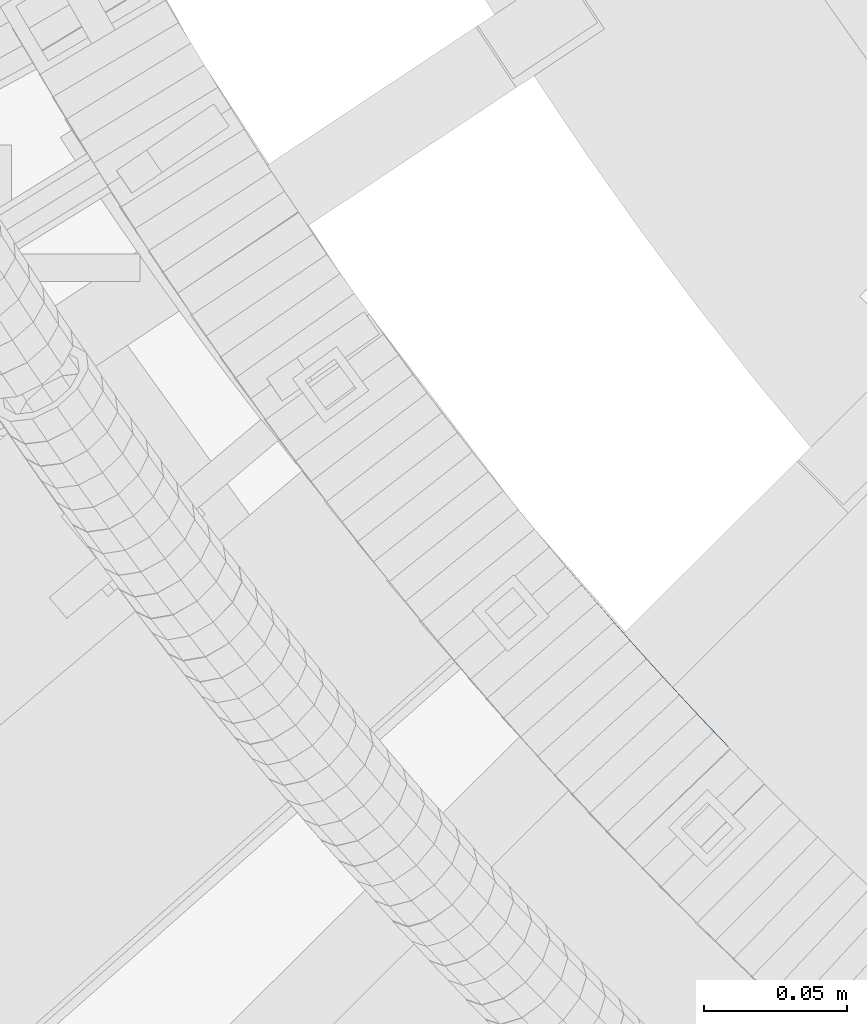
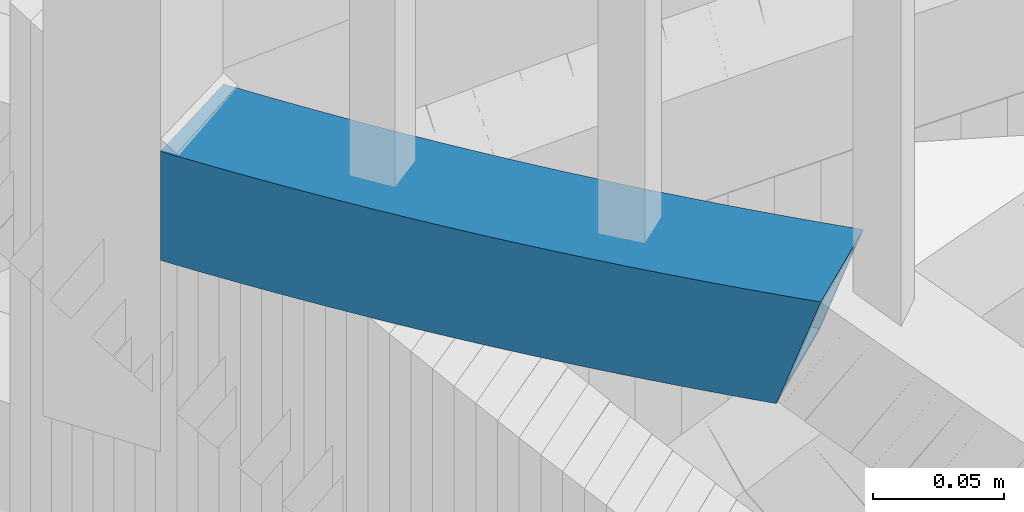
# One storey, part 474 of 975: 1 beam.
"""IFC2X3 building model written with IfcOpenShell, lengths in millimetres."""

from ifc_helpers import new_model, si_unit, frame, origin_with_axes, place, context, subcontext, project, spatial, faceted_brep, material, type_object, element, save


model = new_model("IFC2X3")

# Units and contexts
model_context = context("Model", 3, precision=1e-05, world=origin_with_axes())
body_context = subcontext(model_context, "Body", "Model", "MODEL_VIEW")
ifc_project = project(units=[si_unit("LENGTHUNIT", "METRE", prefix="MILLI"), si_unit("AREAUNIT", "SQUARE_METRE"), si_unit("VOLUMEUNIT", "CUBIC_METRE"), si_unit("MASSUNIT", "GRAM", prefix="KILO"), si_unit("TIMEUNIT", "SECOND"), si_unit("PLANEANGLEUNIT", "RADIAN"), si_unit("SOLIDANGLEUNIT", "STERADIAN"), si_unit("THERMODYNAMICTEMPERATUREUNIT", "DEGREE_CELSIUS"), si_unit("LUMINOUSINTENSITYUNIT", "LUMEN")], contexts=[model_context])

# Site, building, storey
site_placement = place(None, origin_with_axes())
site = spatial("IfcSite", under=ifc_project, at=site_placement, CompositionType="ELEMENT")
building_placement = place(site_placement, origin_with_axes())
building = spatial("IfcBuilding", under=site, at=building_placement, Name="Undefined", CompositionType="ELEMENT")
storey_placement = place(building_placement, origin_with_axes())
storey = spatial("IfcBuildingStorey", under=building, at=storey_placement, Name="Undefined", CompositionType="ELEMENT", Elevation=0.0)

# Beam
ifc_material = material()
beam_type = type_object("IfcBeamType", Name="HSS2X2X.188_TUBES", PredefinedType="NOTDEFINED")
beam_placement = place(storey_placement, frame((33730.3437735476, 2432.37434502385, 4254.5), z_axis=(0.0, 0.0, 1.0), x_axis=(-0.614732272176384, 0.788735845226309, 0.0)))
element("IfcBeam", 1, at=beam_placement, inside=storey, type_object=beam_type, material=ifc_material, Name="HANDRAIL", ObjectType="HSS2X2X.188_TUBES", context=body_context, shape_type="Brep", body=[
    faceted_brep([(7.5286119618213, 26.3140467708836, 25.3999999999996), (7.5286119618213, 26.3140467708836, 15.6138958555184), (4.14886245549496, 25.9706449751648, 25.3999999999996), (12.6480240895398, 26.8155101962911, 25.3999999999996), (12.6480240895398, 26.8155101962911, 0.793814656849463), (17.7692162116036, 27.298456724704, 25.3999999999996), (17.7692162116036, 27.298456724704, -14.0281842069107), (260.234750728057, -21.9957919031367, 25.3999999999996), (260.234750728057, -21.9957919031367, -25.3999999999996), (265.177804815132, -22.407887995374, -25.3999999999996), (265.177804815132, -22.407887995374, 25.3999999999996), (255.290238677531, -21.6015743500284, 25.3999999999996), (255.290238677531, -21.6015743500284, -25.3999999999996), (250.344333328252, -21.2252404916435, 25.3999999999996), (250.344333328252, -21.2252404916435, -25.3999999999996), (245.397099363145, -20.866795249709, 25.3999999999996), (245.397099363145, -20.866795249709, -25.3999999999996), (240.448601482509, -20.5262433119933, 25.3999999999996), (240.448601482509, -20.5262433119933, -25.3999999999996), (235.498904403161, -20.2035891322703, 25.3999999999996), (235.498904403161, -20.2035891322703, -25.3999999999996), (230.548072857622, -19.8988369302206, 25.3999999999996), (230.548072857622, -19.8988369302206, -25.3999999999996), (225.596171593232, -19.6119906914282, 25.3999999999996), (225.596171593232, -19.6119906914282, -25.3999999999996), (220.643265371331, -19.3430541672897, 25.3999999999996), (220.643265371331, -19.3430541672897, -25.3999999999996), (215.689418966394, -19.0920308749701, 25.3999999999996), (215.689418966394, -19.0920308749701, -25.3999999999996), (210.734697165204, -18.8589240973779, 25.3999999999996), (210.734697165204, -18.8589240973779, -25.3999999999996), (205.779164765976, -18.643736883103, 25.3999999999996), (205.779164765976, -18.643736883103, -25.3999999999996), (200.822886577538, -18.4464720463693, 25.3999999999996), (200.822886577538, -18.4464720463693, -25.3999999999996), (195.865927418476, -18.2671321670205, 25.3999999999996), (195.865927418476, -18.2671321670205, -25.3999999999996), (190.908352116261, -18.1057195904941, 25.3999999999996), (190.908352116261, -18.1057195904941, -25.3999999999996), (185.950225506444, -17.9622364277457, 25.3999999999996), (185.950225506444, -17.9622364277457, -25.3999999999996), (180.991612431775, -17.8366845552518, 25.3999999999996), (180.991612431775, -17.8366845552518, -25.3999999999996), (176.032577741364, -17.7290656149999, 25.3999999999996), (176.032577741364, -17.7290656149999, -25.3999999999996), (171.073186289846, -17.6393810144327, 25.3999999999996), (171.073186289846, -17.6393810144327, -25.3999999999996), (166.113502936514, -17.567631926453, 25.3999999999996), (166.113502936514, -17.567631926453, -25.3999999999996), (161.153592544477, -17.513819289401, 25.3999999999996), (161.153592544477, -17.513819289401, -25.3999999999996), (156.193519979806, -17.4779438070473, 25.3999999999996), (156.193519979806, -17.4779438070473, -25.3999999999996), (151.233350110724, -17.4600059485674, 25.3999999999996), (151.233350110724, -17.4600059485674, -25.3999999999996), (146.273147806685, -17.4600059485565, 25.3999999999996), (146.273147806685, -17.4600059485565, -25.3999999999996), (141.312977937596, -17.4779438070145, 25.3999999999996), (141.312977937596, -17.4779438070145, -25.3999999999996), (136.352905372933, -17.5138192893464, 25.3999999999996), (136.352905372933, -17.5138192893464, -25.3999999999996), (131.392994980895, -17.5676319263766, 25.3999999999996), (131.392994980895, -17.5676319263766, -25.3999999999996), (126.433311627556, -17.6393810143345, 25.3999999999996), (126.433311627556, -17.6393810143345, -25.3999999999996), (121.473920176039, -17.7290656148798, 25.3999999999996), (121.473920176039, -17.7290656148798, -25.3999999999996), (116.514885485631, -17.8366845551136, 25.3999999999996), (116.514885485631, -17.8366845551136, -25.3999999999996), (111.556272410962, -17.962236427582, 25.3999999999996), (111.556272410962, -17.962236427582, -25.3999999999996), (106.598145801145, -18.1057195903122, 25.3999999999996), (106.598145801145, -18.1057195903122, -25.3999999999996), (101.640570498934, -18.2671321668167, 25.3999999999996), (101.640570498934, -18.2671321668167, -25.3999999999996), (96.6836113398676, -18.4464720461401, 25.3999999999996), (96.6836113398676, -18.4464720461401, -25.3999999999996), (91.7273331514261, -18.6437368828556, 25.3999999999996), (91.7273331514261, -18.6437368828556, -25.3999999999996), (86.7718007522053, -18.8589240971087, 25.3999999999996), (86.7718007522053, -18.8589240971087, -25.3999999999996), (81.8170789510077, -19.092030874679, 25.3999999999996), (81.8170789510077, -19.092030874679, -25.3999999999996), (76.8632325460712, -19.3430541669768, 25.3999999999996), (76.8632325460712, -19.3430541669768, -25.3999999999996), (71.9103263241741, -19.6119906910899, 25.3999999999996), (71.9103263241741, -19.6119906910899, -25.3999999999996), (66.9584250597836, -19.8988369298604, 25.3999999999996), (66.9584250597836, -19.8988369298604, -25.3999999999996), (62.0075935142377, -20.2035891318883, 25.3999999999996), (62.0075935142377, -20.2035891318883, -25.3999999999996), (57.0578964348933, -20.5262433115895, 25.3999999999996), (57.0578964348933, -20.5262433115895, -25.3999999999996), (52.1093985542502, -20.866795249287, 25.3999999999996), (52.1093985542502, -20.866795249287, -25.3999999999996), (47.1621645891464, -21.225240491196, 25.3999999999996), (47.1621645891464, -21.225240491196, -25.3999999999996), (42.2162592398672, -21.6015743495627, 25.3999999999996), (42.2162592398672, -21.6015743495627, -25.3999999999996), (37.2717471893448, -21.9957919026492, 25.3999999999996), (37.2717471893448, -21.9957919026492, -25.3999999999996), (32.3286931022631, -22.4078879948647, 25.3999999999996), (32.3286931022631, -22.4078879948647, -25.3999999999996), (27.3871616242759, -22.8378572367656, 25.3999999999996), (27.3871616242759, -22.8378572367656, -25.3999999999996), (7.63755400110313, -24.7363497333245, 25.3999999999996), (7.20128584808845, -24.7822716471164, 25.3999999999996), (7.63755400110313, -24.7363497333245, 24.1365044695722), (12.5723489973643, -24.2349464606777, 25.3999999999996), (12.5723489973643, -24.2349464606777, 9.8477479582516), (17.5089249776647, -23.7513924433151, 25.3999999999996), (17.5089249776647, -23.7513924433151, -4.44304462617947), (22.4472173810864, -23.2856940052006, 25.3999999999996), (22.4472173810864, -23.2856940052006, -18.7356863876621), (24.7503262013524, -23.0769028203904, -25.3999999999996), (265.582056745192, -17.6625759269082, -20.6374999999998), (265.582056745192, -17.6625759269082, 20.6374999999998), (270.028364761973, -18.0494551152515, 20.6374999999998), (270.028364761973, -18.0494551152515, -20.6374999999998), (260.621839275871, -17.2490489454685, -20.6374999999998), (260.621839275871, -17.2490489454685, 20.6374999999998), (255.660158780724, -16.85346258141, -20.6374999999998), (255.660158780724, -16.85346258141, 20.6374999999998), (250.697080148988, -16.4758220082331, -20.6374999999998), (250.697080148988, -16.4758220082331, 20.6374999999998), (245.732668288165, -16.1161321647669, -20.6374999999998), (245.732668288165, -16.1161321647669, 20.6374999999998), (240.766988123221, -15.7743977550454, -20.6374999999998), (240.766988123221, -15.7743977550454, 20.6374999999998), (235.800104595684, -15.4506232483072, -20.6374999999998), (235.800104595684, -15.4506232483072, 20.6374999999998), (230.83208266283, -15.1448128788943, -20.6374999999998), (230.83208266283, -15.1448128788943, 20.6374999999998), (225.862987296827, -14.8569706462185, -20.6374999999998), (225.862987296827, -14.8569706462185, 20.6374999999998), (220.892883483881, -14.587100314704, -20.6374999999998), (220.892883483881, -14.587100314704, 20.6374999999998), (215.921836223373, -14.3352054137285, -20.6374999999998), (215.921836223373, -14.3352054137285, 20.6374999999998), (210.949910527033, -14.1012892376057, -20.6374999999998), (210.949910527033, -14.1012892376057, 20.6374999999998), (205.97717141809, -13.8853548455008, -20.6374999999998), (205.97717141809, -13.8853548455008, 20.6374999999998), (201.003683930387, -13.6874050614206, -20.6374999999998), (201.003683930387, -13.6874050614206, 20.6374999999998), (196.029513107576, -13.5074424741579, -20.6374999999998), (196.029513107576, -13.5074424741579, 20.6374999999998), (191.054724002228, -13.3454694372922, -20.6374999999998), (191.054724002228, -13.3454694372922, 20.6374999999998), (186.079381675019, -13.2014880691167, -20.6374999999998), (186.079381675019, -13.2014880691167, 20.6374999999998), (181.103551193839, -13.0755002526203, -20.6374999999998), (181.103551193839, -13.0755002526203, 20.6374999999998), (176.127297632978, -12.9675076354906, -20.6374999999998), (176.127297632978, -12.9675076354906, 20.6374999999998), (171.150686072255, -12.8775116300603, -20.6374999999998), (171.150686072255, -12.8775116300603, 20.6374999999998), (166.173781596161, -12.8055134133101, -20.6374999999998), (166.173781596161, -12.8055134133101, 20.6374999999998), (161.196649293041, -12.7515139268216, -20.6374999999998), (161.196649293041, -12.7515139268216, 20.6374999999998), (156.219354254197, -12.7155138768176, -20.6374999999998), (156.219354254197, -12.7155138768176, 20.6374999999998), (151.241961573061, -12.6975137341033, -20.6374999999998), (151.241961573061, -12.6975137341033, 20.6374999999998), (146.264536344359, -12.697513734096, -20.6374999999998), (146.264536344359, -12.697513734096, 20.6374999999998), (141.287143663223, -12.7155138767885, -20.6374999999998), (141.287143663223, -12.7155138767885, 20.6374999999998), (136.309848624376, -12.7515139267671, -20.6374999999998), (136.309848624376, -12.7515139267671, 20.6374999999998), (131.332716321256, -12.8055134132264, -20.6374999999998), (131.332716321256, -12.8055134132264, 20.6374999999998), (126.355811845166, -12.8775116299694, -20.6374999999998), (126.355811845166, -12.8775116299694, 20.6374999999998), (121.379200284438, -12.9675076353778, -20.6374999999998), (121.379200284438, -12.9675076353778, 20.6374999999998), (116.402946723581, -13.075500252482, -20.6374999999998), (116.402946723581, -13.075500252482, 20.6374999999998), (111.427116242401, -13.2014880689494, -20.6374999999998), (111.427116242401, -13.2014880689494, 20.6374999999998), (106.451773915189, -13.3454694371067, -20.6374999999998), (106.451773915189, -13.3454694371067, 20.6374999999998), (101.476984809837, -13.5074424739541, -20.6374999999998), (101.476984809837, -13.5074424739541, 20.6374999999998), (96.5028139870265, -13.6874050611877, -20.6374999999998), (96.5028139870265, -13.6874050611877, 20.6374999999998), (91.529326499327, -13.8853548452462, -20.6374999999998), (91.529326499327, -13.8853548452462, 20.6374999999998), (86.5565873903797, -14.1012892373328, -20.6374999999998), (86.5565873903797, -14.1012892373328, 20.6374999999998), (81.5846616940435, -14.3352054134375, -20.6374999999998), (81.5846616940435, -14.3352054134375, 20.6374999999998), (76.6136144335323, -14.5871003143875, -20.6374999999998), (76.6136144335323, -14.5871003143875, 20.6374999999998), (71.6435106205827, -14.8569706458802, -20.6374999999998), (71.6435106205827, -14.8569706458802, 20.6374999999998), (66.6744152545834, -15.1448128785341, -20.6374999999998), (66.6744152545834, -15.1448128785341, 20.6374999999998), (61.7063933217287, -15.4506232479253, -20.6374999999998), (61.7063933217287, -15.4506232479253, 20.6374999999998), (56.7395097941881, -15.7743977546452, -20.6374999999998), (56.7395097941881, -15.7743977546452, 20.6374999999998), (51.7738296292446, -16.1161321643449, -20.6374999999998), (51.7738296292446, -16.1161321643449, 20.6374999999998), (46.8094177684216, -16.4758220077929, -20.6374999999998), (46.8094177684216, -16.4758220077929, 20.6374999999998), (41.8463391366822, -16.8534625809407, -20.6374999999998), (41.8463391366822, -16.8534625809407, 20.6374999999998), (36.8846586415384, -17.249048944981, -20.6374999999998), (36.8846586415384, -17.249048944981, 20.6374999999998), (31.9244411722138, -17.6625759263989, -20.6374999999998), (31.9244411722138, -17.6625759263989, 20.6374999999998), (26.965751598811, -18.0940381170622, -20.6374999999998), (26.965751598811, -18.0940381170622, 20.6374999999998), (22.0086547714454, -18.5434298742766, 20.6374999999998), (22.8184172146866, -18.4700198562787, -20.6374999999998), (22.0086547714454, -18.5434298742766, -18.2943580582169), (17.0532155194014, -19.0107453208511, 20.6374999999998), (17.0532155194014, -19.0107453208511, -3.95208906839616), (12.099498650281, -19.4959783452214, 20.6374999999998), (12.099498650281, -19.4959783452214, 10.3883243236205), (8.55982178591876, -19.8556296712122, 20.6374999999998), (6.07980522722573, 21.3798273531102, 20.6374999999998), (8.00146230890095, 21.5750786554236, 20.6374999999998), (13.1037335477959, 22.0748630738235, 20.6374999999998), (18.2077788212409, 22.5561925937727, 20.6374999999998), (23.3135313781495, 23.0190609204037, 20.6374999999998), (28.4209244451049, 23.4634620002944, 20.6374999999998), (33.5298912272301, 23.8893900215262, 20.6374999999998), (38.6403649090789, 24.2968394137788, 20.6374999999998), (43.7522786555019, 24.68580484841, 20.6374999999998), (48.8655656124902, 25.0562812384924, 20.6374999999998), (53.9801589081071, 25.4082637389038, 20.6374999999998), (59.0959916533066, 25.7417477464005, 20.6374999999998), (64.2129969428534, 26.0567288996463, 20.6374999999998), (69.3311078561674, 26.3532030792994, 20.6374999999998), (74.4502574582039, 26.6311664080531, 20.6374999999998), (79.5703788003411, 26.8906152506679, 20.6374999999998), (84.6914049212537, 27.1315462140628, 20.6374999999998), (89.8132688477672, 27.3539561473117, 20.6374999999998), (94.9359035957677, 27.5578421417376, 20.6374999999998), (100.059242171053, 27.743201530895, 20.6374999999998), (105.183217570218, 27.9100318906421, 20.6374999999998), (110.307762781522, 28.058331039163, 20.6374999999998), (115.43281078578, 28.1880970369821, 20.6374999999998), (120.558294557228, 28.2993281870113, 20.6374999999998), (125.684147064418, 28.3920230345684, 20.6374999999998), (130.810301271045, 28.4661803673735, 20.6374999999998), (135.936690136892, 28.5217992155995, 20.6374999999998), (141.063246618658, 28.5588788518544, 20.6374999999998), (146.189903670849, 28.5774187912066, 20.6374999999998), (151.316594246662, 28.5774187911993, 20.6374999999998), (156.443251298857, 28.558878851818, 20.6374999999998), (161.569807780623, 28.5217992155413, 20.6374999999998), (166.696196646466, 28.4661803672934, 20.6374999999998), (171.822350853101, 28.3920230344665, 20.6374999999998), (176.948203360284, 28.2993281868912, 20.6374999999998), (182.073687131731, 28.1880970368329, 20.6374999999998), (187.198735135993, 28.058331038992, 20.6374999999998), (192.323280347297, 27.910031890453, 20.6374999999998), (197.447255746458, 27.743201530684, 20.6374999999998), (202.57059432174, 27.5578421415048, 20.6374999999998), (207.693229069748, 27.353956147057, 20.6374999999998), (212.815092996258, 27.1315462137791, 20.6374999999998), (217.93611911717, 26.890615250366, 20.6374999999998), (223.056240459307, 26.631166407722, 20.6374999999998), (228.17539006134, 26.3532030789538, 20.6374999999998), (233.293500974651, 26.0567288992825, 20.6374999999998), (238.410506264197, 25.7417477460076, 20.6374999999998), (243.526339009401, 25.408263738489, 20.6374999999998), (248.640932305014, 25.0562812380522, 20.6374999999998), (253.754219262009, 24.685804847948, 20.6374999999998), (258.866133008425, 24.2968394133022, 20.6374999999998), (263.976606690274, 23.8893900210169, 20.6374999999998), (269.085573472403, 23.4634619997669, 20.6374999999998), (274.192966539351, 23.019060919858, 20.6374999999998), (8.00146230890095, 21.5750786554236, 15.0733194901495), (13.1037335477959, 22.0748630738235, 0.302859099065245), (18.2077788212409, 22.5561925937727, -14.469512536356), (23.3135313781495, 23.0190609204037, -20.6374999999998), (20.3393631309191, 22.7494340114717, -20.6374999999998), (28.4209244451049, 23.4634620002944, -20.6374999999998), (33.5298912272301, 23.8893900215262, -20.6374999999998), (38.6403649090789, 24.2968394137788, -20.6374999999998), (43.7522786555019, 24.68580484841, -20.6374999999998), (48.8655656124902, 25.0562812384924, -20.6374999999998), (53.9801589081071, 25.4082637389038, -20.6374999999998), (59.0959916533066, 25.7417477464005, -20.6374999999998), (64.2129969428534, 26.0567288996463, -20.6374999999998), (69.3311078561674, 26.3532030792994, -20.6374999999998), (74.4502574582039, 26.6311664080531, -20.6374999999998), (79.5703788003411, 26.8906152506679, -20.6374999999998), (84.6914049212537, 27.1315462140628, -20.6374999999998), (89.8132688477672, 27.3539561473117, -20.6374999999998), (94.9359035957677, 27.5578421417376, -20.6374999999998), (100.059242171053, 27.743201530895, -20.6374999999998), (105.183217570218, 27.9100318906421, -20.6374999999998), (110.307762781522, 28.058331039163, -20.6374999999998), (115.43281078578, 28.1880970369821, -20.6374999999998), (120.558294557228, 28.2993281870113, -20.6374999999998), (125.684147064418, 28.3920230345684, -20.6374999999998), (130.810301271045, 28.4661803673735, -20.6374999999998), (135.936690136892, 28.5217992155995, -20.6374999999998), (141.063246618658, 28.5588788518544, -20.6374999999998), (146.189903670849, 28.5774187912066, -20.6374999999998), (151.316594246662, 28.5774187911993, -20.6374999999998), (156.443251298857, 28.558878851818, -20.6374999999998), (161.569807780623, 28.5217992155413, -20.6374999999998), (166.696196646466, 28.4661803672934, -20.6374999999998), (171.822350853101, 28.3920230344665, -20.6374999999998), (176.948203360284, 28.2993281868912, -20.6374999999998), (182.073687131731, 28.1880970368329, -20.6374999999998), (187.198735135993, 28.058331038992, -20.6374999999998), (192.323280347297, 27.910031890453, -20.6374999999998), (197.447255746458, 27.743201530684, -20.6374999999998), (202.57059432174, 27.5578421415048, -20.6374999999998), (207.693229069748, 27.353956147057, -20.6374999999998), (212.815092996258, 27.1315462137791, -20.6374999999998), (217.93611911717, 26.890615250366, -20.6374999999998), (223.056240459307, 26.631166407722, -20.6374999999998), (228.17539006134, 26.3532030789538, -20.6374999999998), (233.293500974651, 26.0567288992825, -20.6374999999998), (238.410506264197, 25.7417477460076, -20.6374999999998), (243.526339009401, 25.408263738489, -20.6374999999998), (248.640932305014, 25.0562812380522, -20.6374999999998), (253.754219262009, 24.685804847948, -20.6374999999998), (258.866133008425, 24.2968394133022, -20.6374999999998), (263.976606690274, 23.8893900210169, -20.6374999999998), (269.085573472403, 23.4634619997669, -20.6374999999998), (274.192966539351, 23.019060919858, -20.6374999999998), (21.6991827136299, 27.6547327091394, -25.3999999999996), (22.8921213526883, 27.7628800401144, 25.3999999999996), (22.8921213526883, 27.7628800401144, -25.3999999999996), (28.0166725150484, 28.2087740687602, 25.3999999999996), (28.0166725150484, 28.2087740687602, -25.3999999999996), (33.1428026794274, 28.636132979198, 25.3999999999996), (33.1428026794274, 28.636132979198, -25.3999999999996), (38.2704448058976, 29.0449511824045, 25.3999999999996), (38.2704448058976, 29.0449511824045, -25.3999999999996), (43.3995318347734, 29.4352233318132, 25.3999999999996), (43.3995318347734, 29.4352233318132, -25.3999999999996), (48.5299966874845, 29.8069443234344, 25.3999999999996), (48.5299966874845, 29.8069443234344, -25.3999999999996), (53.6617722674055, 30.1601092958517, 25.3999999999996), (53.6617722674055, 30.1601092958517, -25.3999999999996), (58.7947914608012, 30.4947136303599, 25.3999999999996), (58.7947914608012, 30.4947136303599, -25.3999999999996), (63.9289871376568, 30.8107529509762, 25.3999999999996), (63.9289871376568, 30.8107529509762, -25.3999999999996), (69.0642921525796, 31.1082231245164, 25.3999999999996), (69.0642921525796, 31.1082231245164, -25.3999999999996), (74.2006393456613, 31.3871202606388, 25.3999999999996), (74.2006393456613, 31.3871202606388, -25.3999999999996), (79.3379615433732, 31.6474407119094, 25.3999999999996), (79.3379615433732, 31.6474407119094, -25.3999999999996), (84.4761915594281, 31.8891810738351, 25.3999999999996), (84.4761915594281, 31.8891810738351, -25.3999999999996), (89.6152621956644, 32.1123381849175, 25.3999999999996), (89.6152621956644, 32.1123381849175, -25.3999999999996), (94.7551062429302, 32.3169091266936, 25.3999999999996), (94.7551062429302, 32.3169091266936, -25.3999999999996), (99.89565648196, 32.5028912237613, 25.3999999999996), (99.89565648196, 32.5028912237613, -25.3999999999996), (105.036845684252, 32.6702820438441, 25.3999999999996), (105.036845684252, 32.6702820438441, -25.3999999999996), (110.178606612953, 32.8190793977883, 25.3999999999996), (110.178606612953, 32.8190793977883, -25.3999999999996), (115.320872023727, 32.94928133961, 25.3999999999996), (115.320872023727, 32.94928133961, -25.3999999999996), (120.463574665628, 33.0608861665169, 25.3999999999996), (120.463574665628, 33.0608861665169, -25.3999999999996), (125.60664728202, 33.1538924189372, 25.3999999999996), (125.60664728202, 33.1538924189372, -25.3999999999996), (130.750022611406, 33.22829888052, 25.3999999999996), (130.750022611406, 33.22829888052, -25.3999999999996), (135.893633388336, 33.2841045781825, 25.3999999999996), (135.893633388336, 33.2841045781825, -25.3999999999996), (141.037412344282, 33.3213087820805, 25.3999999999996), (141.037412344282, 33.3213087820805, -25.3999999999996), (146.181292208519, 33.3399110056671, 25.3999999999996), (146.181292208519, 33.3399110056671, -25.3999999999996), (151.325205709007, 33.3399110056598, 25.3999999999996), (151.325205709007, 33.3399110056598, -25.3999999999996), (156.469085573244, 33.3213087820477, 25.3999999999996), (156.469085573244, 33.3213087820477, -25.3999999999996), (161.61286452919, 33.2841045781206, 25.3999999999996), (161.61286452919, 33.2841045781206, -25.3999999999996), (166.756475306123, 33.2282988804436, 25.3999999999996), (166.756475306123, 33.2282988804436, -25.3999999999996), (171.899850635502, 33.1538924188317, 25.3999999999996), (171.899850635502, 33.1538924188317, -25.3999999999996), (177.042923251891, 33.0608861663895, 25.3999999999996), (177.042923251891, 33.0608861663895, -25.3999999999996), (182.185625893799, 32.9492813394645, 25.3999999999996), (182.185625893799, 32.9492813394645, -25.3999999999996), (187.327891304565, 32.819079397621, 25.3999999999996), (187.327891304565, 32.819079397621, -25.3999999999996), (192.469652233267, 32.6702820436585, 25.3999999999996), (192.469652233267, 32.6702820436585, -25.3999999999996), (197.610841435559, 32.5028912235503, 25.3999999999996), (197.610841435559, 32.5028912235503, -25.3999999999996), (202.751391674592, 32.3169091264535, 25.3999999999996), (202.751391674592, 32.3169091264535, -25.3999999999996), (207.891235721858, 32.1123381846592, 25.3999999999996), (207.891235721858, 32.1123381846592, -25.3999999999996), (213.03030635809, 31.8891810735549, 25.3999999999996), (213.03030635809, 31.8891810735549, -25.3999999999996), (218.168536374145, 31.6474407116075, 25.3999999999996), (218.168536374145, 31.6474407116075, -25.3999999999996), (223.305858571854, 31.3871202603113, 25.3999999999996), (223.305858571854, 31.3871202603113, -25.3999999999996), (228.442205764939, 31.1082231241708, 25.3999999999996), (228.442205764939, 31.1082231241708, -25.3999999999996), (233.577510779862, 30.8107529506051, 25.3999999999996), (233.577510779862, 30.8107529506051, -25.3999999999996), (238.711706456721, 30.494713629967, 25.3999999999996), (238.711706456721, 30.494713629967, -25.3999999999996), (243.844725650113, 30.1601092954334, 25.3999999999996), (243.844725650113, 30.1601092954334, -25.3999999999996), (248.976501230034, 29.8069443229906, 25.3999999999996), (248.976501230034, 29.8069443229906, -25.3999999999996), (254.106966082738, 29.4352233313548, 25.3999999999996), (254.106966082738, 29.4352233313548, -25.3999999999996), (259.236053111621, 29.0449511819206, 25.3999999999996), (259.236053111621, 29.0449511819206, -25.3999999999996), (264.363695238088, 28.6361329786887, 25.3999999999996), (264.363695238088, 28.6361329786887, -25.3999999999996), (269.489825402467, 28.2087740682327, 25.3999999999996), (269.489825402467, 28.2087740682327, -25.3999999999996), (274.614376564823, 27.7628800395614, 25.3999999999996), (274.614376564823, 27.7628800395614, -25.3999999999996), (274.931298487441, 27.7341490898398, 25.3999999999996), (274.931298487441, 27.7341490898398, -25.3999999999996), (269.521152042555, -22.7858084281615, -25.3999999999996), (269.521152042555, -22.7858084281615, 25.3999999999996)], [[[0, 1, 2]], [[0, 3, 4, 1]], [[3, 5, 6, 4]], [[7, 8, 9, 10]], [[11, 12, 8, 7]], [[13, 14, 12, 11]], [[15, 16, 14, 13]], [[17, 18, 16, 15]], [[19, 20, 18, 17]], [[21, 22, 20, 19]], [[23, 24, 22, 21]], [[25, 26, 24, 23]], [[27, 28, 26, 25]], [[29, 30, 28, 27]], [[31, 32, 30, 29]], [[33, 34, 32, 31]], [[35, 36, 34, 33]], [[37, 38, 36, 35]], [[39, 40, 38, 37]], [[41, 42, 40, 39]], [[43, 44, 42, 41]], [[45, 46, 44, 43]], [[47, 48, 46, 45]], [[49, 50, 48, 47]], [[51, 52, 50, 49]], [[53, 54, 52, 51]], [[55, 56, 54, 53]], [[57, 58, 56, 55]], [[59, 60, 58, 57]], [[61, 62, 60, 59]], [[63, 64, 62, 61]], [[65, 66, 64, 63]], [[67, 68, 66, 65]], [[69, 70, 68, 67]], [[71, 72, 70, 69]], [[73, 74, 72, 71]], [[75, 76, 74, 73]], [[77, 78, 76, 75]], [[79, 80, 78, 77]], [[81, 82, 80, 79]], [[83, 84, 82, 81]], [[85, 86, 84, 83]], [[87, 88, 86, 85]], [[89, 90, 88, 87]], [[91, 92, 90, 89]], [[93, 94, 92, 91]], [[95, 96, 94, 93]], [[97, 98, 96, 95]], [[99, 100, 98, 97]], [[101, 102, 100, 99]], [[103, 104, 102, 101]], [[105, 106, 107]], [[108, 105, 107, 109]], [[110, 108, 109, 111]], [[112, 110, 111, 113]], [[104, 103, 112, 113, 114]], [[115, 116, 117, 118]], [[119, 120, 116, 115]], [[121, 122, 120, 119]], [[123, 124, 122, 121]], [[125, 126, 124, 123]], [[127, 128, 126, 125]], [[129, 130, 128, 127]], [[131, 132, 130, 129]], [[133, 134, 132, 131]], [[135, 136, 134, 133]], [[137, 138, 136, 135]], [[139, 140, 138, 137]], [[141, 142, 140, 139]], [[143, 144, 142, 141]], [[145, 146, 144, 143]], [[147, 148, 146, 145]], [[149, 150, 148, 147]], [[151, 152, 150, 149]], [[153, 154, 152, 151]], [[155, 156, 154, 153]], [[157, 158, 156, 155]], [[159, 160, 158, 157]], [[161, 162, 160, 159]], [[163, 164, 162, 161]], [[165, 166, 164, 163]], [[167, 168, 166, 165]], [[169, 170, 168, 167]], [[171, 172, 170, 169]], [[173, 174, 172, 171]], [[175, 176, 174, 173]], [[177, 178, 176, 175]], [[179, 180, 178, 177]], [[181, 182, 180, 179]], [[183, 184, 182, 181]], [[185, 186, 184, 183]], [[187, 188, 186, 185]], [[189, 190, 188, 187]], [[191, 192, 190, 189]], [[193, 194, 192, 191]], [[195, 196, 194, 193]], [[197, 198, 196, 195]], [[199, 200, 198, 197]], [[201, 202, 200, 199]], [[203, 204, 202, 201]], [[205, 206, 204, 203]], [[207, 208, 206, 205]], [[209, 210, 208, 207]], [[211, 212, 210, 209]], [[213, 214, 212, 211]], [[215, 214, 213, 216, 217]], [[218, 215, 217, 219]], [[220, 218, 219, 221]], [[220, 221, 222]], [[116, 120, 122, 124, 126, 128, 130, 132, 134, 136, 138, 140, 142, 144, 146, 148, 150, 152, 154, 156, 158, 160, 162, 164, 166, 168, 170, 172, 174, 176, 178, 180, 182, 184, 186, 188, 190, 192, 194, 196, 198, 200, 202, 204, 206, 208, 210, 212, 214, 215, 218, 220, 222, 223, 224, 225, 226, 227, 228, 229, 230, 231, 232, 233, 234, 235, 236, 237, 238, 239, 240, 241, 242, 243, 244, 245, 246, 247, 248, 249, 250, 251, 252, 253, 254, 255, 256, 257, 258, 259, 260, 261, 262, 263, 264, 265, 266, 267, 268, 269, 270, 271, 272, 273, 274, 275, 276, 117]], [[224, 223, 277]], [[225, 224, 277, 278]], [[226, 225, 278, 279]], [[280, 227, 226, 279, 281]], [[227, 280, 282, 228]], [[228, 282, 283, 229]], [[229, 283, 284, 230]], [[230, 284, 285, 231]], [[231, 285, 286, 232]], [[232, 286, 287, 233]], [[233, 287, 288, 234]], [[234, 288, 289, 235]], [[235, 289, 290, 236]], [[236, 290, 291, 237]], [[237, 291, 292, 238]], [[238, 292, 293, 239]], [[239, 293, 294, 240]], [[240, 294, 295, 241]], [[241, 295, 296, 242]], [[242, 296, 297, 243]], [[243, 297, 298, 244]], [[244, 298, 299, 245]], [[245, 299, 300, 246]], [[246, 300, 301, 247]], [[247, 301, 302, 248]], [[248, 302, 303, 249]], [[249, 303, 304, 250]], [[250, 304, 305, 251]], [[251, 305, 306, 252]], [[252, 306, 307, 253]], [[253, 307, 308, 254]], [[254, 308, 309, 255]], [[255, 309, 310, 256]], [[256, 310, 311, 257]], [[257, 311, 312, 258]], [[258, 312, 313, 259]], [[259, 313, 314, 260]], [[260, 314, 315, 261]], [[261, 315, 316, 262]], [[262, 316, 317, 263]], [[263, 317, 318, 264]], [[264, 318, 319, 265]], [[265, 319, 320, 266]], [[266, 320, 321, 267]], [[267, 321, 322, 268]], [[268, 322, 323, 269]], [[269, 323, 324, 270]], [[270, 324, 325, 271]], [[271, 325, 326, 272]], [[272, 326, 327, 273]], [[273, 327, 328, 274]], [[274, 328, 329, 275]], [[275, 329, 330, 276]], [[118, 117, 276, 330]], [[329, 328, 327, 326, 325, 324, 323, 322, 321, 320, 319, 318, 317, 316, 315, 314, 313, 312, 311, 310, 309, 308, 307, 306, 305, 304, 303, 302, 301, 300, 299, 298, 297, 296, 295, 294, 293, 292, 291, 290, 289, 288, 287, 286, 285, 284, 283, 282, 280, 281, 216, 213, 211, 209, 207, 205, 203, 201, 199, 197, 195, 193, 191, 189, 187, 185, 183, 181, 179, 177, 175, 173, 171, 169, 167, 165, 163, 161, 159, 157, 155, 153, 151, 149, 147, 145, 143, 141, 139, 137, 135, 133, 131, 129, 127, 125, 123, 121, 119, 115, 118, 330]], [[111, 109, 107, 106, 2, 1, 4, 6, 331, 114, 113], [279, 278, 277, 223, 222, 221, 219, 217, 216, 281]], [[5, 332, 333, 331, 6]], [[333, 332, 334, 335]], [[335, 334, 336, 337]], [[337, 336, 338, 339]], [[339, 338, 340, 341]], [[341, 340, 342, 343]], [[343, 342, 344, 345]], [[345, 344, 346, 347]], [[347, 346, 348, 349]], [[349, 348, 350, 351]], [[351, 350, 352, 353]], [[353, 352, 354, 355]], [[355, 354, 356, 357]], [[357, 356, 358, 359]], [[359, 358, 360, 361]], [[361, 360, 362, 363]], [[363, 362, 364, 365]], [[365, 364, 366, 367]], [[367, 366, 368, 369]], [[369, 368, 370, 371]], [[371, 370, 372, 373]], [[373, 372, 374, 375]], [[375, 374, 376, 377]], [[377, 376, 378, 379]], [[379, 378, 380, 381]], [[381, 380, 382, 383]], [[383, 382, 384, 385]], [[385, 384, 386, 387]], [[387, 386, 388, 389]], [[389, 388, 390, 391]], [[391, 390, 392, 393]], [[393, 392, 394, 395]], [[395, 394, 396, 397]], [[397, 396, 398, 399]], [[399, 398, 400, 401]], [[401, 400, 402, 403]], [[403, 402, 404, 405]], [[405, 404, 406, 407]], [[407, 406, 408, 409]], [[409, 408, 410, 411]], [[411, 410, 412, 413]], [[413, 412, 414, 415]], [[415, 414, 416, 417]], [[417, 416, 418, 419]], [[419, 418, 420, 421]], [[421, 420, 422, 423]], [[423, 422, 424, 425]], [[425, 424, 426, 427]], [[427, 426, 428, 429]], [[429, 428, 430, 431]], [[431, 430, 432, 433]], [[9, 8, 12, 14, 16, 18, 20, 22, 24, 26, 28, 30, 32, 34, 36, 38, 40, 42, 44, 46, 48, 50, 52, 54, 56, 58, 60, 62, 64, 66, 68, 70, 72, 74, 76, 78, 80, 82, 84, 86, 88, 90, 92, 94, 96, 98, 100, 102, 104, 114, 331, 333, 335, 337, 339, 341, 343, 345, 347, 349, 351, 353, 355, 357, 359, 361, 363, 365, 367, 369, 371, 373, 375, 377, 379, 381, 383, 385, 387, 389, 391, 393, 395, 397, 399, 401, 403, 405, 407, 409, 411, 413, 415, 417, 419, 421, 423, 425, 427, 429, 431, 433, 434]], [[10, 9, 434, 435]], [[430, 428, 426, 424, 422, 420, 418, 416, 414, 412, 410, 408, 406, 404, 402, 400, 398, 396, 394, 392, 390, 388, 386, 384, 382, 380, 378, 376, 374, 372, 370, 368, 366, 364, 362, 360, 358, 356, 354, 352, 350, 348, 346, 344, 342, 340, 338, 336, 334, 332, 5, 3, 0, 2, 106, 105, 108, 110, 112, 103, 101, 99, 97, 95, 93, 91, 89, 87, 85, 83, 81, 79, 77, 75, 73, 71, 69, 67, 65, 63, 61, 59, 57, 55, 53, 51, 49, 47, 45, 43, 41, 39, 37, 35, 33, 31, 29, 27, 25, 23, 21, 19, 17, 15, 13, 11, 7, 10, 435, 432]], [[434, 433, 432, 435]]]),
])

save(model, "model.ifc")
